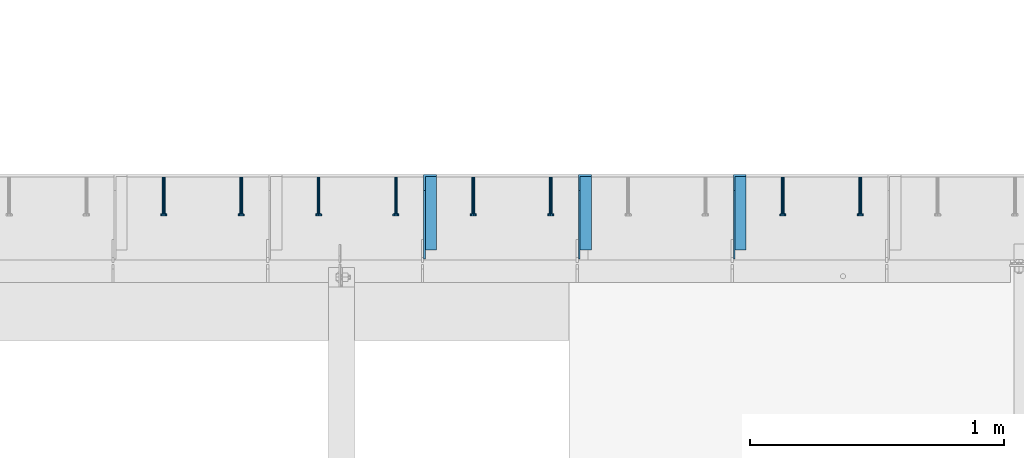
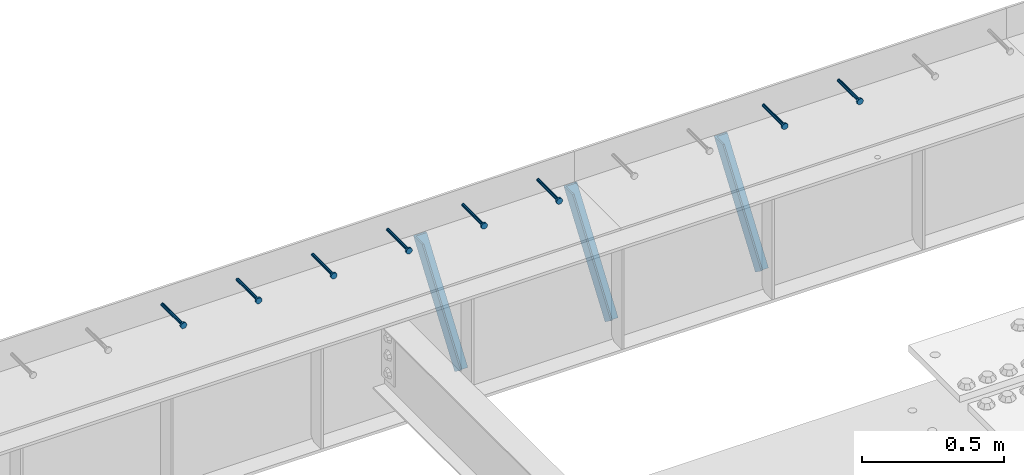
# One storey, part 1346 of 1763: 8 beams, 3 members, 9 elements without a shape of their own.
"""IFC2X3 building model written with IfcOpenShell, lengths in millimetres."""

from ifc_helpers import new_model, si_unit, frame, origin_with_axes, place, context, subcontext, project, spatial, faceted_brep, material, type_object, element, aggregate, save


model = new_model("IFC2X3")

# Units and contexts
model_context = context("Model", 3, precision=1e-05, world=origin_with_axes())
body_context = subcontext(model_context, "Body", "Model", "MODEL_VIEW")
ifc_project = project(units=[si_unit("LENGTHUNIT", "METRE", prefix="MILLI"), si_unit("AREAUNIT", "SQUARE_METRE"), si_unit("VOLUMEUNIT", "CUBIC_METRE"), si_unit("MASSUNIT", "GRAM", prefix="KILO"), si_unit("TIMEUNIT", "SECOND"), si_unit("PLANEANGLEUNIT", "RADIAN"), si_unit("SOLIDANGLEUNIT", "STERADIAN"), si_unit("THERMODYNAMICTEMPERATUREUNIT", "DEGREE_CELSIUS"), si_unit("LUMINOUSINTENSITYUNIT", "LUMEN")], contexts=[model_context])

# Site, building, storey
site_placement = place(None, origin_with_axes())
site = spatial("IfcSite", under=ifc_project, at=site_placement, CompositionType="ELEMENT")
building_placement = place(site_placement, origin_with_axes())
building = spatial("IfcBuilding", under=site, at=building_placement, Name="Undefined", CompositionType="ELEMENT")
storey_placement = place(building_placement, origin_with_axes())
storey = spatial("IfcBuildingStorey", under=building, at=storey_placement, Name="Undefined", CompositionType="ELEMENT", Elevation=0.0)

# Assembly, beam
assembly_1_placement = place(storey_placement, origin_with_axes())
assembly_1 = element("IfcElementAssembly", 1, at=assembly_1_placement, inside=storey, Name="HEADED STUD ANCHOR", AssemblyPlace="NOTDEFINED", PredefinedType="RIGID_FRAME")
ifc_material_1 = material(Name="STEEL/A108")
beam_type = type_object("IfcBeamType", PredefinedType="NOTDEFINED")
beam_1_placement = place(assembly_1_placement, frame((-62275.4747736983, 53984.5250183106, 5264.23140606069), z_axis=(0.0, 0.0, 1.0), x_axis=(0.0, -1.0, 0.0)))
beam_1 = element("IfcBeam", 2, at=beam_1_placement, type_object=beam_type, material=ifc_material_1, Name="HEADED STUD ANCHOR", context=body_context, shape_type="Brep", body=[
    faceted_brep([(0.0, -3.1800000667572, 5.5), (0.0, -5.5, 3.1800000667572), (141.732000000002, -5.5, 3.1800000667572), (141.732000000002, -3.1800000667572, 5.5), (0.0, -6.34999999999491, 1.45519152283669e-11), (141.732000000002, -6.34999990463257, 0.0), (0.0, -5.5, -3.1800000667572), (141.732000000002, -5.5, -3.1800000667572), (0.0, -3.1800000667572, -5.5), (141.732000000002, -3.1800000667572, -5.5), (0.0, 0.0, -6.34999990463257), (141.732000000002, 0.0, -6.34999990463257), (0.0, 3.1800000667572, -5.5), (141.732000000002, 3.1800000667572, -5.5), (0.0, 5.5, -3.1800000667572), (141.732000000002, 5.5, -3.1800000667572), (0.0, 6.34999999999491, -2.91038304567337e-11), (141.732000000002, 6.34999990463257, 0.0), (0.0, 5.5, 3.1800000667572), (141.732000000002, 5.5, 3.1800000667572), (0.0, 3.1800000667572, 5.5), (141.732000000002, 3.1800000667572, 5.5), (0.0, 0.0, 6.34999990463257), (141.732000000002, 0.0, 6.34999990463257), (144.780000000001, -10.9899997711182, 6.34999990463257), (144.780000000001, -6.34000015258789, 10.9899997711182), (144.780000000001, -12.6999998092651, 0.0), (144.780000000001, -10.9899997711182, -6.34999990463257), (144.780000000001, -6.34000015258789, -10.9899997711182), (144.780000000001, 0.0, -12.6899995803833), (144.780000000001, 6.34000015258789, -10.9899997711182), (144.780000000001, 10.9899997711182, -6.34999990463257), (144.780000000001, 12.6999998092651, 0.0), (144.780000000001, 10.9899997711182, 6.34999990463257), (144.780000000001, 6.34000015258789, 10.9899997711182), (144.780000000001, 0.0, 12.6899995803833), (152.400000000001, -10.9899997711182, 6.34999990463257), (152.400000000001, -6.34000015258789, 10.9899997711182), (152.400000000001, -12.6999998092651, 0.0), (152.400000000001, -10.9899997711182, -6.34999990463257), (152.400000000001, -6.34000015258789, -10.9899997711182), (152.400000000001, 0.0, -12.6899995803833), (152.400000000001, 6.34000015258789, -10.9899997711182), (152.400000000001, 10.9899997711182, -6.34999990463257), (152.400000000001, 12.6999998092651, 0.0), (152.400000000001, 10.9899997711182, 6.34999990463257), (152.400000000001, 6.34000015258789, 10.9899997711182), (152.400000000001, 0.0, 12.6899995803833)], [[[0, 1, 2, 3]], [[1, 4, 5, 2]], [[4, 6, 7, 5]], [[6, 8, 9, 7]], [[8, 10, 11, 9]], [[10, 12, 13, 11]], [[12, 14, 15, 13]], [[14, 16, 17, 15]], [[16, 18, 19, 17]], [[18, 20, 21, 19]], [[20, 22, 23, 21]], [[22, 0, 3, 23]], [[22, 20, 18, 16, 14, 12, 10, 8, 6, 4, 1, 0]], [[3, 2, 24, 25]], [[2, 5, 26, 24]], [[5, 7, 27, 26]], [[7, 9, 28, 27]], [[9, 11, 29, 28]], [[11, 13, 30, 29]], [[13, 15, 31, 30]], [[15, 17, 32, 31]], [[17, 19, 33, 32]], [[19, 21, 34, 33]], [[21, 23, 35, 34]], [[23, 3, 25, 35]], [[25, 24, 36, 37]], [[24, 26, 38, 36]], [[26, 27, 39, 38]], [[27, 28, 40, 39]], [[28, 29, 41, 40]], [[29, 30, 42, 41]], [[30, 31, 43, 42]], [[31, 32, 44, 43]], [[32, 33, 45, 44]], [[33, 34, 46, 45]], [[34, 35, 47, 46]], [[35, 25, 37, 47]], [[38, 39, 40, 41, 42, 43, 44, 45, 46, 47, 37, 36]]]),
])
aggregate(assembly_1, [beam_1])

assembly_2_placement = place(storey_placement, origin_with_axes())
assembly_2 = element("IfcElementAssembly", 3, at=assembly_2_placement, inside=storey, Name="HEADED STUD ANCHOR", AssemblyPlace="NOTDEFINED", PredefinedType="RIGID_FRAME")
beam_2_placement = place(assembly_2_placement, frame((-62580.2747736984, 53984.5250183106, 5264.23140606069), z_axis=(0.0, 0.0, 1.0), x_axis=(0.0, -1.0, 0.0)))
beam_2 = element("IfcBeam", 4, at=beam_2_placement, type_object=beam_type, material=ifc_material_1, Name="HEADED STUD ANCHOR", context=body_context, shape_type="Brep", body=[
    faceted_brep([(0.0, -3.1800000667572, 5.5), (0.0, -5.5, 3.1800000667572), (141.732000000002, -5.5, 3.1800000667572), (141.732000000002, -3.1800000667572, 5.5), (0.0, -6.34999999999491, 1.45519152283669e-11), (141.732000000002, -6.34999990463257, 0.0), (0.0, -5.5, -3.1800000667572), (141.732000000002, -5.5, -3.1800000667572), (0.0, -3.1800000667572, -5.5), (141.732000000002, -3.1800000667572, -5.5), (0.0, 0.0, -6.34999990463257), (141.732000000002, 0.0, -6.34999990463257), (0.0, 3.1800000667572, -5.5), (141.732000000002, 3.1800000667572, -5.5), (0.0, 5.5, -3.1800000667572), (141.732000000002, 5.5, -3.1800000667572), (0.0, 6.34999999999491, -2.91038304567337e-11), (141.732000000002, 6.34999990463257, 0.0), (0.0, 5.5, 3.1800000667572), (141.732000000002, 5.5, 3.1800000667572), (0.0, 3.1800000667572, 5.5), (141.732000000002, 3.1800000667572, 5.5), (0.0, 0.0, 6.34999990463257), (141.732000000002, 0.0, 6.34999990463257), (144.780000000001, -10.9899997711182, 6.34999990463257), (144.780000000001, -6.34000015258789, 10.9899997711182), (144.780000000001, -12.6999998092651, 0.0), (144.780000000001, -10.9899997711182, -6.34999990463257), (144.780000000001, -6.34000015258789, -10.9899997711182), (144.780000000001, 0.0, -12.6899995803833), (144.780000000001, 6.34000015258789, -10.9899997711182), (144.780000000001, 10.9899997711182, -6.34999990463257), (144.780000000001, 12.6999998092651, 0.0), (144.780000000001, 10.9899997711182, 6.34999990463257), (144.780000000001, 6.34000015258789, 10.9899997711182), (144.780000000001, 0.0, 12.6899995803833), (152.400000000001, -10.9899997711182, 6.34999990463257), (152.400000000001, -6.34000015258789, 10.9899997711182), (152.400000000001, -12.6999998092651, 0.0), (152.400000000001, -10.9899997711182, -6.34999990463257), (152.400000000001, -6.34000015258789, -10.9899997711182), (152.400000000001, 0.0, -12.6899995803833), (152.400000000001, 6.34000015258789, -10.9899997711182), (152.400000000001, 10.9899997711182, -6.34999990463257), (152.400000000001, 12.6999998092651, 0.0), (152.400000000001, 10.9899997711182, 6.34999990463257), (152.400000000001, 6.34000015258789, 10.9899997711182), (152.400000000001, 0.0, 12.6899995803833)], [[[0, 1, 2, 3]], [[1, 4, 5, 2]], [[4, 6, 7, 5]], [[6, 8, 9, 7]], [[8, 10, 11, 9]], [[10, 12, 13, 11]], [[12, 14, 15, 13]], [[14, 16, 17, 15]], [[16, 18, 19, 17]], [[18, 20, 21, 19]], [[20, 22, 23, 21]], [[22, 0, 3, 23]], [[22, 20, 18, 16, 14, 12, 10, 8, 6, 4, 1, 0]], [[3, 2, 24, 25]], [[2, 5, 26, 24]], [[5, 7, 27, 26]], [[7, 9, 28, 27]], [[9, 11, 29, 28]], [[11, 13, 30, 29]], [[13, 15, 31, 30]], [[15, 17, 32, 31]], [[17, 19, 33, 32]], [[19, 21, 34, 33]], [[21, 23, 35, 34]], [[23, 3, 25, 35]], [[25, 24, 36, 37]], [[24, 26, 38, 36]], [[26, 27, 39, 38]], [[27, 28, 40, 39]], [[28, 29, 41, 40]], [[29, 30, 42, 41]], [[30, 31, 43, 42]], [[31, 32, 44, 43]], [[32, 33, 45, 44]], [[33, 34, 46, 45]], [[34, 35, 47, 46]], [[35, 25, 37, 47]], [[38, 39, 40, 41, 42, 43, 44, 45, 46, 47, 37, 36]]]),
])
aggregate(assembly_2, [beam_2])

assembly_3_placement = place(storey_placement, origin_with_axes())
assembly_3 = element("IfcElementAssembly", 5, at=assembly_3_placement, inside=storey, Name="HEADED STUD ANCHOR", AssemblyPlace="NOTDEFINED", PredefinedType="RIGID_FRAME")
beam_3_placement = place(assembly_3_placement, frame((-63494.6747736984, 53984.5250183106, 5264.23140606069), z_axis=(0.0, 0.0, 1.0), x_axis=(0.0, -1.0, 0.0)))
beam_3 = element("IfcBeam", 6, at=beam_3_placement, type_object=beam_type, material=ifc_material_1, Name="HEADED STUD ANCHOR", context=body_context, shape_type="Brep", body=[
    faceted_brep([(0.0, -3.1800000667572, 5.5), (0.0, -5.5, 3.1800000667572), (141.732000000002, -5.5, 3.1800000667572), (141.732000000002, -3.1800000667572, 5.5), (0.0, -6.34999999999491, 1.45519152283669e-11), (141.732000000002, -6.34999990463257, 0.0), (0.0, -5.5, -3.1800000667572), (141.732000000002, -5.5, -3.1800000667572), (0.0, -3.1800000667572, -5.5), (141.732000000002, -3.1800000667572, -5.5), (0.0, 0.0, -6.34999990463257), (141.732000000002, 0.0, -6.34999990463257), (0.0, 3.1800000667572, -5.5), (141.732000000002, 3.1800000667572, -5.5), (0.0, 5.5, -3.1800000667572), (141.732000000002, 5.5, -3.1800000667572), (0.0, 6.34999999999491, -2.91038304567337e-11), (141.732000000002, 6.34999990463257, 0.0), (0.0, 5.5, 3.1800000667572), (141.732000000002, 5.5, 3.1800000667572), (0.0, 3.1800000667572, 5.5), (141.732000000002, 3.1800000667572, 5.5), (0.0, 0.0, 6.34999990463257), (141.732000000002, 0.0, 6.34999990463257), (144.780000000001, -10.9899997711182, 6.34999990463257), (144.780000000001, -6.34000015258789, 10.9899997711182), (144.780000000001, -12.6999998092651, 0.0), (144.780000000001, -10.9899997711182, -6.34999990463257), (144.780000000001, -6.34000015258789, -10.9899997711182), (144.780000000001, 0.0, -12.6899995803833), (144.780000000001, 6.34000015258789, -10.9899997711182), (144.780000000001, 10.9899997711182, -6.34999990463257), (144.780000000001, 12.6999998092651, 0.0), (144.780000000001, 10.9899997711182, 6.34999990463257), (144.780000000001, 6.34000015258789, 10.9899997711182), (144.780000000001, 0.0, 12.6899995803833), (152.400000000001, -10.9899997711182, 6.34999990463257), (152.400000000001, -6.34000015258789, 10.9899997711182), (152.400000000001, -12.6999998092651, 0.0), (152.400000000001, -10.9899997711182, -6.34999990463257), (152.400000000001, -6.34000015258789, -10.9899997711182), (152.400000000001, 0.0, -12.6899995803833), (152.400000000001, 6.34000015258789, -10.9899997711182), (152.400000000001, 10.9899997711182, -6.34999990463257), (152.400000000001, 12.6999998092651, 0.0), (152.400000000001, 10.9899997711182, 6.34999990463257), (152.400000000001, 6.34000015258789, 10.9899997711182), (152.400000000001, 0.0, 12.6899995803833)], [[[0, 1, 2, 3]], [[1, 4, 5, 2]], [[4, 6, 7, 5]], [[6, 8, 9, 7]], [[8, 10, 11, 9]], [[10, 12, 13, 11]], [[12, 14, 15, 13]], [[14, 16, 17, 15]], [[16, 18, 19, 17]], [[18, 20, 21, 19]], [[20, 22, 23, 21]], [[22, 0, 3, 23]], [[22, 20, 18, 16, 14, 12, 10, 8, 6, 4, 1, 0]], [[3, 2, 24, 25]], [[2, 5, 26, 24]], [[5, 7, 27, 26]], [[7, 9, 28, 27]], [[9, 11, 29, 28]], [[11, 13, 30, 29]], [[13, 15, 31, 30]], [[15, 17, 32, 31]], [[17, 19, 33, 32]], [[19, 21, 34, 33]], [[21, 23, 35, 34]], [[23, 3, 25, 35]], [[25, 24, 36, 37]], [[24, 26, 38, 36]], [[26, 27, 39, 38]], [[27, 28, 40, 39]], [[28, 29, 41, 40]], [[29, 30, 42, 41]], [[30, 31, 43, 42]], [[31, 32, 44, 43]], [[32, 33, 45, 44]], [[33, 34, 46, 45]], [[34, 35, 47, 46]], [[35, 25, 37, 47]], [[38, 39, 40, 41, 42, 43, 44, 45, 46, 47, 37, 36]]]),
])
aggregate(assembly_3, [beam_3])

assembly_4_placement = place(storey_placement, origin_with_axes())
assembly_4 = element("IfcElementAssembly", 7, at=assembly_4_placement, inside=storey, Name="HEADED STUD ANCHOR", AssemblyPlace="NOTDEFINED", PredefinedType="RIGID_FRAME")
beam_4_placement = place(assembly_4_placement, frame((-63799.4747736983, 53984.5250183106, 5264.23140606069), z_axis=(0.0, 0.0, 1.0), x_axis=(0.0, -1.0, 0.0)))
beam_4 = element("IfcBeam", 8, at=beam_4_placement, type_object=beam_type, material=ifc_material_1, Name="HEADED STUD ANCHOR", context=body_context, shape_type="Brep", body=[
    faceted_brep([(0.0, -3.1800000667572, 5.5), (0.0, -5.5, 3.1800000667572), (141.732000000002, -5.5, 3.1800000667572), (141.732000000002, -3.1800000667572, 5.5), (0.0, -6.34999999999491, 1.45519152283669e-11), (141.732000000002, -6.34999990463257, 0.0), (0.0, -5.5, -3.1800000667572), (141.732000000002, -5.5, -3.1800000667572), (0.0, -3.1800000667572, -5.5), (141.732000000002, -3.1800000667572, -5.5), (0.0, 0.0, -6.34999990463257), (141.732000000002, 0.0, -6.34999990463257), (0.0, 3.1800000667572, -5.5), (141.732000000002, 3.1800000667572, -5.5), (0.0, 5.5, -3.1800000667572), (141.732000000002, 5.5, -3.1800000667572), (0.0, 6.34999999999491, -2.91038304567337e-11), (141.732000000002, 6.34999990463257, 0.0), (0.0, 5.5, 3.1800000667572), (141.732000000002, 5.5, 3.1800000667572), (0.0, 3.1800000667572, 5.5), (141.732000000002, 3.1800000667572, 5.5), (0.0, 0.0, 6.34999990463257), (141.732000000002, 0.0, 6.34999990463257), (144.780000000001, -10.9899997711182, 6.34999990463257), (144.780000000001, -6.34000015258789, 10.9899997711182), (144.780000000001, -12.6999998092651, 0.0), (144.780000000001, -10.9899997711182, -6.34999990463257), (144.780000000001, -6.34000015258789, -10.9899997711182), (144.780000000001, 0.0, -12.6899995803833), (144.780000000001, 6.34000015258789, -10.9899997711182), (144.780000000001, 10.9899997711182, -6.34999990463257), (144.780000000001, 12.6999998092651, 0.0), (144.780000000001, 10.9899997711182, 6.34999990463257), (144.780000000001, 6.34000015258789, 10.9899997711182), (144.780000000001, 0.0, 12.6899995803833), (152.400000000001, -10.9899997711182, 6.34999990463257), (152.400000000001, -6.34000015258789, 10.9899997711182), (152.400000000001, -12.6999998092651, 0.0), (152.400000000001, -10.9899997711182, -6.34999990463257), (152.400000000001, -6.34000015258789, -10.9899997711182), (152.400000000001, 0.0, -12.6899995803833), (152.400000000001, 6.34000015258789, -10.9899997711182), (152.400000000001, 10.9899997711182, -6.34999990463257), (152.400000000001, 12.6999998092651, 0.0), (152.400000000001, 10.9899997711182, 6.34999990463257), (152.400000000001, 6.34000015258789, 10.9899997711182), (152.400000000001, 0.0, 12.6899995803833)], [[[0, 1, 2, 3]], [[1, 4, 5, 2]], [[4, 6, 7, 5]], [[6, 8, 9, 7]], [[8, 10, 11, 9]], [[10, 12, 13, 11]], [[12, 14, 15, 13]], [[14, 16, 17, 15]], [[16, 18, 19, 17]], [[18, 20, 21, 19]], [[20, 22, 23, 21]], [[22, 0, 3, 23]], [[22, 20, 18, 16, 14, 12, 10, 8, 6, 4, 1, 0]], [[3, 2, 24, 25]], [[2, 5, 26, 24]], [[5, 7, 27, 26]], [[7, 9, 28, 27]], [[9, 11, 29, 28]], [[11, 13, 30, 29]], [[13, 15, 31, 30]], [[15, 17, 32, 31]], [[17, 19, 33, 32]], [[19, 21, 34, 33]], [[21, 23, 35, 34]], [[23, 3, 25, 35]], [[25, 24, 36, 37]], [[24, 26, 38, 36]], [[26, 27, 39, 38]], [[27, 28, 40, 39]], [[28, 29, 41, 40]], [[29, 30, 42, 41]], [[30, 31, 43, 42]], [[31, 32, 44, 43]], [[32, 33, 45, 44]], [[33, 34, 46, 45]], [[34, 35, 47, 46]], [[35, 25, 37, 47]], [[38, 39, 40, 41, 42, 43, 44, 45, 46, 47, 37, 36]]]),
])
aggregate(assembly_4, [beam_4])

assembly_5_placement = place(storey_placement, origin_with_axes())
assembly_5 = element("IfcElementAssembly", 9, at=assembly_5_placement, inside=storey, Name="HEADED STUD ANCHOR", AssemblyPlace="NOTDEFINED", PredefinedType="RIGID_FRAME")
beam_5_placement = place(assembly_5_placement, frame((-64104.2747736984, 53984.5250183106, 5264.23140606069), z_axis=(0.0, 0.0, 1.0), x_axis=(0.0, -1.0, 0.0)))
beam_5 = element("IfcBeam", 10, at=beam_5_placement, type_object=beam_type, material=ifc_material_1, Name="HEADED STUD ANCHOR", context=body_context, shape_type="Brep", body=[
    faceted_brep([(0.0, -3.1800000667572, 5.5), (0.0, -5.5, 3.1800000667572), (141.732000000002, -5.5, 3.1800000667572), (141.732000000002, -3.1800000667572, 5.5), (0.0, -6.34999999999491, 1.45519152283669e-11), (141.732000000002, -6.34999990463257, 0.0), (0.0, -5.5, -3.1800000667572), (141.732000000002, -5.5, -3.1800000667572), (0.0, -3.1800000667572, -5.5), (141.732000000002, -3.1800000667572, -5.5), (0.0, 0.0, -6.34999990463257), (141.732000000002, 0.0, -6.34999990463257), (0.0, 3.1800000667572, -5.5), (141.732000000002, 3.1800000667572, -5.5), (0.0, 5.5, -3.1800000667572), (141.732000000002, 5.5, -3.1800000667572), (0.0, 6.34999999999491, -2.91038304567337e-11), (141.732000000002, 6.34999990463257, 0.0), (0.0, 5.5, 3.1800000667572), (141.732000000002, 5.5, 3.1800000667572), (0.0, 3.1800000667572, 5.5), (141.732000000002, 3.1800000667572, 5.5), (0.0, 0.0, 6.34999990463257), (141.732000000002, 0.0, 6.34999990463257), (144.780000000001, -10.9899997711182, 6.34999990463257), (144.780000000001, -6.34000015258789, 10.9899997711182), (144.780000000001, -12.6999998092651, 0.0), (144.780000000001, -10.9899997711182, -6.34999990463257), (144.780000000001, -6.34000015258789, -10.9899997711182), (144.780000000001, 0.0, -12.6899995803833), (144.780000000001, 6.34000015258789, -10.9899997711182), (144.780000000001, 10.9899997711182, -6.34999990463257), (144.780000000001, 12.6999998092651, 0.0), (144.780000000001, 10.9899997711182, 6.34999990463257), (144.780000000001, 6.34000015258789, 10.9899997711182), (144.780000000001, 0.0, 12.6899995803833), (152.400000000001, -10.9899997711182, 6.34999990463257), (152.400000000001, -6.34000015258789, 10.9899997711182), (152.400000000001, -12.6999998092651, 0.0), (152.400000000001, -10.9899997711182, -6.34999990463257), (152.400000000001, -6.34000015258789, -10.9899997711182), (152.400000000001, 0.0, -12.6899995803833), (152.400000000001, 6.34000015258789, -10.9899997711182), (152.400000000001, 10.9899997711182, -6.34999990463257), (152.400000000001, 12.6999998092651, 0.0), (152.400000000001, 10.9899997711182, 6.34999990463257), (152.400000000001, 6.34000015258789, 10.9899997711182), (152.400000000001, 0.0, 12.6899995803833)], [[[0, 1, 2, 3]], [[1, 4, 5, 2]], [[4, 6, 7, 5]], [[6, 8, 9, 7]], [[8, 10, 11, 9]], [[10, 12, 13, 11]], [[12, 14, 15, 13]], [[14, 16, 17, 15]], [[16, 18, 19, 17]], [[18, 20, 21, 19]], [[20, 22, 23, 21]], [[22, 0, 3, 23]], [[22, 20, 18, 16, 14, 12, 10, 8, 6, 4, 1, 0]], [[3, 2, 24, 25]], [[2, 5, 26, 24]], [[5, 7, 27, 26]], [[7, 9, 28, 27]], [[9, 11, 29, 28]], [[11, 13, 30, 29]], [[13, 15, 31, 30]], [[15, 17, 32, 31]], [[17, 19, 33, 32]], [[19, 21, 34, 33]], [[21, 23, 35, 34]], [[23, 3, 25, 35]], [[25, 24, 36, 37]], [[24, 26, 38, 36]], [[26, 27, 39, 38]], [[27, 28, 40, 39]], [[28, 29, 41, 40]], [[29, 30, 42, 41]], [[30, 31, 43, 42]], [[31, 32, 44, 43]], [[32, 33, 45, 44]], [[33, 34, 46, 45]], [[34, 35, 47, 46]], [[35, 25, 37, 47]], [[38, 39, 40, 41, 42, 43, 44, 45, 46, 47, 37, 36]]]),
])
aggregate(assembly_5, [beam_5])

assembly_6_placement = place(storey_placement, origin_with_axes())
assembly_6 = element("IfcElementAssembly", 11, at=assembly_6_placement, inside=storey, Name="HEADED STUD ANCHOR", AssemblyPlace="NOTDEFINED", PredefinedType="RIGID_FRAME")
beam_6_placement = place(assembly_6_placement, frame((-64409.0747736983, 53984.5250183106, 5264.23140606069), z_axis=(0.0, 0.0, 1.0), x_axis=(0.0, -1.0, 0.0)))
beam_6 = element("IfcBeam", 12, at=beam_6_placement, type_object=beam_type, material=ifc_material_1, Name="HEADED STUD ANCHOR", context=body_context, shape_type="Brep", body=[
    faceted_brep([(0.0, -3.1800000667572, 5.5), (0.0, -5.5, 3.1800000667572), (141.732000000002, -5.5, 3.1800000667572), (141.732000000002, -3.1800000667572, 5.5), (0.0, -6.34999999999491, 1.45519152283669e-11), (141.732000000002, -6.34999990463257, 0.0), (0.0, -5.5, -3.1800000667572), (141.732000000002, -5.5, -3.1800000667572), (0.0, -3.1800000667572, -5.5), (141.732000000002, -3.1800000667572, -5.5), (0.0, 0.0, -6.34999990463257), (141.732000000002, 0.0, -6.34999990463257), (0.0, 3.1800000667572, -5.5), (141.732000000002, 3.1800000667572, -5.5), (0.0, 5.5, -3.1800000667572), (141.732000000002, 5.5, -3.1800000667572), (0.0, 6.34999999999491, -2.91038304567337e-11), (141.732000000002, 6.34999990463257, 0.0), (0.0, 5.5, 3.1800000667572), (141.732000000002, 5.5, 3.1800000667572), (0.0, 3.1800000667572, 5.5), (141.732000000002, 3.1800000667572, 5.5), (0.0, 0.0, 6.34999990463257), (141.732000000002, 0.0, 6.34999990463257), (144.780000000001, -10.9899997711182, 6.34999990463257), (144.780000000001, -6.34000015258789, 10.9899997711182), (144.780000000001, -12.6999998092651, 0.0), (144.780000000001, -10.9899997711182, -6.34999990463257), (144.780000000001, -6.34000015258789, -10.9899997711182), (144.780000000001, 0.0, -12.6899995803833), (144.780000000001, 6.34000015258789, -10.9899997711182), (144.780000000001, 10.9899997711182, -6.34999990463257), (144.780000000001, 12.6999998092651, 0.0), (144.780000000001, 10.9899997711182, 6.34999990463257), (144.780000000001, 6.34000015258789, 10.9899997711182), (144.780000000001, 0.0, 12.6899995803833), (152.400000000001, -10.9899997711182, 6.34999990463257), (152.400000000001, -6.34000015258789, 10.9899997711182), (152.400000000001, -12.6999998092651, 0.0), (152.400000000001, -10.9899997711182, -6.34999990463257), (152.400000000001, -6.34000015258789, -10.9899997711182), (152.400000000001, 0.0, -12.6899995803833), (152.400000000001, 6.34000015258789, -10.9899997711182), (152.400000000001, 10.9899997711182, -6.34999990463257), (152.400000000001, 12.6999998092651, 0.0), (152.400000000001, 10.9899997711182, 6.34999990463257), (152.400000000001, 6.34000015258789, 10.9899997711182), (152.400000000001, 0.0, 12.6899995803833)], [[[0, 1, 2, 3]], [[1, 4, 5, 2]], [[4, 6, 7, 5]], [[6, 8, 9, 7]], [[8, 10, 11, 9]], [[10, 12, 13, 11]], [[12, 14, 15, 13]], [[14, 16, 17, 15]], [[16, 18, 19, 17]], [[18, 20, 21, 19]], [[20, 22, 23, 21]], [[22, 0, 3, 23]], [[22, 20, 18, 16, 14, 12, 10, 8, 6, 4, 1, 0]], [[3, 2, 24, 25]], [[2, 5, 26, 24]], [[5, 7, 27, 26]], [[7, 9, 28, 27]], [[9, 11, 29, 28]], [[11, 13, 30, 29]], [[13, 15, 31, 30]], [[15, 17, 32, 31]], [[17, 19, 33, 32]], [[19, 21, 34, 33]], [[21, 23, 35, 34]], [[23, 3, 25, 35]], [[25, 24, 36, 37]], [[24, 26, 38, 36]], [[26, 27, 39, 38]], [[27, 28, 40, 39]], [[28, 29, 41, 40]], [[29, 30, 42, 41]], [[30, 31, 43, 42]], [[31, 32, 44, 43]], [[32, 33, 45, 44]], [[33, 34, 46, 45]], [[34, 35, 47, 46]], [[35, 25, 37, 47]], [[38, 39, 40, 41, 42, 43, 44, 45, 46, 47, 37, 36]]]),
])
aggregate(assembly_6, [beam_6])

assembly_7_placement = place(storey_placement, origin_with_axes())
assembly_7 = element("IfcElementAssembly", 13, at=assembly_7_placement, inside=storey, Name="HEADED STUD ANCHOR", AssemblyPlace="NOTDEFINED", PredefinedType="RIGID_FRAME")
beam_7_placement = place(assembly_7_placement, frame((-64713.8747736983, 53984.5250183106, 5264.23140606069), z_axis=(0.0, 0.0, 1.0), x_axis=(0.0, -1.0, 0.0)))
beam_7 = element("IfcBeam", 14, at=beam_7_placement, type_object=beam_type, material=ifc_material_1, Name="HEADED STUD ANCHOR", context=body_context, shape_type="Brep", body=[
    faceted_brep([(0.0, -3.1800000667572, 5.5), (0.0, -5.5, 3.1800000667572), (141.732000000002, -5.5, 3.1800000667572), (141.732000000002, -3.1800000667572, 5.5), (0.0, -6.34999999999491, 1.45519152283669e-11), (141.732000000002, -6.34999990463257, 0.0), (0.0, -5.5, -3.1800000667572), (141.732000000002, -5.5, -3.1800000667572), (0.0, -3.1800000667572, -5.5), (141.732000000002, -3.1800000667572, -5.5), (0.0, 0.0, -6.34999990463257), (141.732000000002, 0.0, -6.34999990463257), (0.0, 3.1800000667572, -5.5), (141.732000000002, 3.1800000667572, -5.5), (0.0, 5.5, -3.1800000667572), (141.732000000002, 5.5, -3.1800000667572), (0.0, 6.34999999999491, -2.91038304567337e-11), (141.732000000002, 6.34999990463257, 0.0), (0.0, 5.5, 3.1800000667572), (141.732000000002, 5.5, 3.1800000667572), (0.0, 3.1800000667572, 5.5), (141.732000000002, 3.1800000667572, 5.5), (0.0, 0.0, 6.34999990463257), (141.732000000002, 0.0, 6.34999990463257), (144.780000000001, -10.9899997711182, 6.34999990463257), (144.780000000001, -6.34000015258789, 10.9899997711182), (144.780000000001, -12.6999998092651, 0.0), (144.780000000001, -10.9899997711182, -6.34999990463257), (144.780000000001, -6.34000015258789, -10.9899997711182), (144.780000000001, 0.0, -12.6899995803833), (144.780000000001, 6.34000015258789, -10.9899997711182), (144.780000000001, 10.9899997711182, -6.34999990463257), (144.780000000001, 12.6999998092651, 0.0), (144.780000000001, 10.9899997711182, 6.34999990463257), (144.780000000001, 6.34000015258789, 10.9899997711182), (144.780000000001, 0.0, 12.6899995803833), (152.400000000001, -10.9899997711182, 6.34999990463257), (152.400000000001, -6.34000015258789, 10.9899997711182), (152.400000000001, -12.6999998092651, 0.0), (152.400000000001, -10.9899997711182, -6.34999990463257), (152.400000000001, -6.34000015258789, -10.9899997711182), (152.400000000001, 0.0, -12.6899995803833), (152.400000000001, 6.34000015258789, -10.9899997711182), (152.400000000001, 10.9899997711182, -6.34999990463257), (152.400000000001, 12.6999998092651, 0.0), (152.400000000001, 10.9899997711182, 6.34999990463257), (152.400000000001, 6.34000015258789, 10.9899997711182), (152.400000000001, 0.0, 12.6899995803833)], [[[0, 1, 2, 3]], [[1, 4, 5, 2]], [[4, 6, 7, 5]], [[6, 8, 9, 7]], [[8, 10, 11, 9]], [[10, 12, 13, 11]], [[12, 14, 15, 13]], [[14, 16, 17, 15]], [[16, 18, 19, 17]], [[18, 20, 21, 19]], [[20, 22, 23, 21]], [[22, 0, 3, 23]], [[22, 20, 18, 16, 14, 12, 10, 8, 6, 4, 1, 0]], [[3, 2, 24, 25]], [[2, 5, 26, 24]], [[5, 7, 27, 26]], [[7, 9, 28, 27]], [[9, 11, 29, 28]], [[11, 13, 30, 29]], [[13, 15, 31, 30]], [[15, 17, 32, 31]], [[17, 19, 33, 32]], [[19, 21, 34, 33]], [[21, 23, 35, 34]], [[23, 3, 25, 35]], [[25, 24, 36, 37]], [[24, 26, 38, 36]], [[26, 27, 39, 38]], [[27, 28, 40, 39]], [[28, 29, 41, 40]], [[29, 30, 42, 41]], [[30, 31, 43, 42]], [[31, 32, 44, 43]], [[32, 33, 45, 44]], [[33, 34, 46, 45]], [[34, 35, 47, 46]], [[35, 25, 37, 47]], [[38, 39, 40, 41, 42, 43, 44, 45, 46, 47, 37, 36]]]),
])
aggregate(assembly_7, [beam_7])

assembly_8_placement = place(storey_placement, origin_with_axes())
assembly_8 = element("IfcElementAssembly", 15, at=assembly_8_placement, inside=storey, Name="HEADED STUD ANCHOR", AssemblyPlace="NOTDEFINED", PredefinedType="RIGID_FRAME")
beam_8_placement = place(assembly_8_placement, frame((-65018.6747736984, 53984.5250183106, 5264.23140606069), z_axis=(0.0, 0.0, 1.0), x_axis=(0.0, -1.0, 0.0)))
beam_8 = element("IfcBeam", 16, at=beam_8_placement, type_object=beam_type, material=ifc_material_1, Name="HEADED STUD ANCHOR", context=body_context, shape_type="Brep", body=[
    faceted_brep([(0.0, -3.1800000667572, 5.5), (0.0, -5.5, 3.1800000667572), (141.732000000002, -5.5, 3.1800000667572), (141.732000000002, -3.1800000667572, 5.5), (0.0, -6.34999999999491, 1.45519152283669e-11), (141.732000000002, -6.34999990463257, 0.0), (0.0, -5.5, -3.1800000667572), (141.732000000002, -5.5, -3.1800000667572), (0.0, -3.1800000667572, -5.5), (141.732000000002, -3.1800000667572, -5.5), (0.0, 0.0, -6.34999990463257), (141.732000000002, 0.0, -6.34999990463257), (0.0, 3.1800000667572, -5.5), (141.732000000002, 3.1800000667572, -5.5), (0.0, 5.5, -3.1800000667572), (141.732000000002, 5.5, -3.1800000667572), (0.0, 6.34999999999491, -2.91038304567337e-11), (141.732000000002, 6.34999990463257, 0.0), (0.0, 5.5, 3.1800000667572), (141.732000000002, 5.5, 3.1800000667572), (0.0, 3.1800000667572, 5.5), (141.732000000002, 3.1800000667572, 5.5), (0.0, 0.0, 6.34999990463257), (141.732000000002, 0.0, 6.34999990463257), (144.780000000001, -10.9899997711182, 6.34999990463257), (144.780000000001, -6.34000015258789, 10.9899997711182), (144.780000000001, -12.6999998092651, 0.0), (144.780000000001, -10.9899997711182, -6.34999990463257), (144.780000000001, -6.34000015258789, -10.9899997711182), (144.780000000001, 0.0, -12.6899995803833), (144.780000000001, 6.34000015258789, -10.9899997711182), (144.780000000001, 10.9899997711182, -6.34999990463257), (144.780000000001, 12.6999998092651, 0.0), (144.780000000001, 10.9899997711182, 6.34999990463257), (144.780000000001, 6.34000015258789, 10.9899997711182), (144.780000000001, 0.0, 12.6899995803833), (152.400000000001, -10.9899997711182, 6.34999990463257), (152.400000000001, -6.34000015258789, 10.9899997711182), (152.400000000001, -12.6999998092651, 0.0), (152.400000000001, -10.9899997711182, -6.34999990463257), (152.400000000001, -6.34000015258789, -10.9899997711182), (152.400000000001, 0.0, -12.6899995803833), (152.400000000001, 6.34000015258789, -10.9899997711182), (152.400000000001, 10.9899997711182, -6.34999990463257), (152.400000000001, 12.6999998092651, 0.0), (152.400000000001, 10.9899997711182, 6.34999990463257), (152.400000000001, 6.34000015258789, 10.9899997711182), (152.400000000001, 0.0, 12.6899995803833)], [[[0, 1, 2, 3]], [[1, 4, 5, 2]], [[4, 6, 7, 5]], [[6, 8, 9, 7]], [[8, 10, 11, 9]], [[10, 12, 13, 11]], [[12, 14, 15, 13]], [[14, 16, 17, 15]], [[16, 18, 19, 17]], [[18, 20, 21, 19]], [[20, 22, 23, 21]], [[22, 0, 3, 23]], [[22, 20, 18, 16, 14, 12, 10, 8, 6, 4, 1, 0]], [[3, 2, 24, 25]], [[2, 5, 26, 24]], [[5, 7, 27, 26]], [[7, 9, 28, 27]], [[9, 11, 29, 28]], [[11, 13, 30, 29]], [[13, 15, 31, 30]], [[15, 17, 32, 31]], [[17, 19, 33, 32]], [[19, 21, 34, 33]], [[21, 23, 35, 34]], [[23, 3, 25, 35]], [[25, 24, 36, 37]], [[24, 26, 38, 36]], [[26, 27, 39, 38]], [[27, 28, 40, 39]], [[28, 29, 41, 40]], [[29, 30, 42, 41]], [[30, 31, 43, 42]], [[31, 32, 44, 43]], [[32, 33, 45, 44]], [[33, 34, 46, 45]], [[34, 35, 47, 46]], [[35, 25, 37, 47]], [[38, 39, 40, 41, 42, 43, 44, 45, 46, 47, 37, 36]]]),
])
aggregate(assembly_8, [beam_8])

# Assembly, members
assembly_9_placement = place(storey_placement, origin_with_axes())
assembly_9 = element("IfcElementAssembly", 17, at=assembly_9_placement, inside=storey, Name="BEAM", AssemblyPlace="NOTDEFINED", PredefinedType="RIGID_FRAME")
ifc_material_2 = material(Name="STEEL/A36")
member_type = type_object("IfcMemberType", Name="L2X2X1/4", PredefinedType="NOTDEFINED")
member_1_placement = place(assembly_9_placement, frame((-62750.1372736984, 53682.7083833994, 4801.55161052493), z_axis=(0.0, -0.814117947745209, 0.580699549818259), x_axis=(0.0, 0.58069954981826, 0.814117947745209)))
member_1 = element("IfcMember", 18, at=member_1_placement, type_object=member_type, material=ifc_material_2, Name="ANGLE", ObjectType="L2X2X1/4", context=body_context, shape_type="Brep", body=[
    faceted_brep([(-1.45519152283669e-11, 25.4000000000015, -25.3999999999869), (1.45519152283669e-11, 25.4000000000015, 25.3999999999796), (464.304493432646, 25.4000000000015, 25.3999999991429), (500.539460322936, 25.4000000000015, -25.4000000009546), (1.45519152283669e-11, 19.0499999999993, 25.3999999999796), (464.304493432646, 19.0500000000029, 25.3999999991429), (-7.27595761418343e-12, 19.0499999999993, -19.0499999999956), (496.010089461648, 19.0500000000029, -19.0500000009415), (-7.27595761418343e-12, -25.4000000000015, -19.0499999999956), (496.010089461648, -25.4000000000015, -19.0500000009415), (-1.45519152283669e-11, -25.4000000000015, -25.3999999999869), (500.539460322936, -25.4000000000015, -25.4000000009546)], [[[0, 1, 2, 3]], [[1, 4, 5, 2]], [[4, 6, 7, 5]], [[6, 8, 9, 7]], [[8, 10, 11, 9]], [[10, 0, 3, 11]], [[5, 7, 9, 11, 3, 2]], [[10, 8, 6, 4, 1, 0]]]),
])
member_2_placement = place(assembly_9_placement, frame((-63969.3372736984, 53682.7083833994, 4801.55161052493), z_axis=(0.0, -0.814117947745209, 0.580699549818259), x_axis=(0.0, 0.58069954981826, 0.814117947745209)))
member_2 = element("IfcMember", 19, at=member_2_placement, type_object=member_type, material=ifc_material_2, Name="ANGLE", ObjectType="L2X2X1/4", context=body_context, shape_type="Brep", body=[
    faceted_brep([(-1.45519152283669e-11, 25.4000000000015, -25.3999999999869), (1.45519152283669e-11, 25.4000000000015, 25.3999999999796), (464.304493432646, 25.4000000000015, 25.3999999991429), (500.539460322936, 25.4000000000015, -25.4000000009546), (1.45519152283669e-11, 19.0499999999993, 25.3999999999796), (464.304493432646, 19.0500000000029, 25.3999999991429), (-7.27595761418343e-12, 19.0499999999993, -19.0499999999956), (496.010089461648, 19.0500000000029, -19.0500000009415), (-7.27595761418343e-12, -25.4000000000015, -19.0499999999956), (496.010089461648, -25.4000000000015, -19.0500000009415), (-1.45519152283669e-11, -25.4000000000015, -25.3999999999869), (500.539460322936, -25.4000000000015, -25.4000000009546)], [[[0, 1, 2, 3]], [[1, 4, 5, 2]], [[4, 6, 7, 5]], [[6, 8, 9, 7]], [[8, 10, 11, 9]], [[10, 0, 3, 11]], [[5, 7, 9, 11, 3, 2]], [[10, 8, 6, 4, 1, 0]]]),
])
member_3_placement = place(assembly_9_placement, frame((-63359.7372736984, 53682.7083833994, 4801.55161052493), z_axis=(0.0, -0.814117947745209, 0.580699549818259), x_axis=(0.0, 0.58069954981826, 0.814117947745209)))
member_3 = element("IfcMember", 20, at=member_3_placement, type_object=member_type, material=ifc_material_2, Name="ANGLE", ObjectType="L2X2X1/4", context=body_context, shape_type="Brep", body=[
    faceted_brep([(-1.45519152283669e-11, 25.4000000000015, -25.3999999999869), (1.45519152283669e-11, 25.4000000000015, 25.3999999999796), (464.304493432646, 25.4000000000015, 25.3999999991429), (500.539460322936, 25.4000000000015, -25.4000000009546), (1.45519152283669e-11, 19.0499999999993, 25.3999999999796), (464.304493432646, 19.0500000000029, 25.3999999991429), (-7.27595761418343e-12, 19.0499999999993, -19.0499999999956), (496.010089461648, 19.0500000000029, -19.0500000009415), (-7.27595761418343e-12, -25.4000000000015, -19.0499999999956), (496.010089461648, -25.4000000000015, -19.0500000009415), (-1.45519152283669e-11, -25.4000000000015, -25.3999999999869), (500.539460322936, -25.4000000000015, -25.4000000009546)], [[[0, 1, 2, 3]], [[1, 4, 5, 2]], [[4, 6, 7, 5]], [[6, 8, 9, 7]], [[8, 10, 11, 9]], [[10, 0, 3, 11]], [[5, 7, 9, 11, 3, 2]], [[10, 8, 6, 4, 1, 0]]]),
])
aggregate(assembly_9, [member_1, member_2, member_3])

save(model, "model.ifc")
